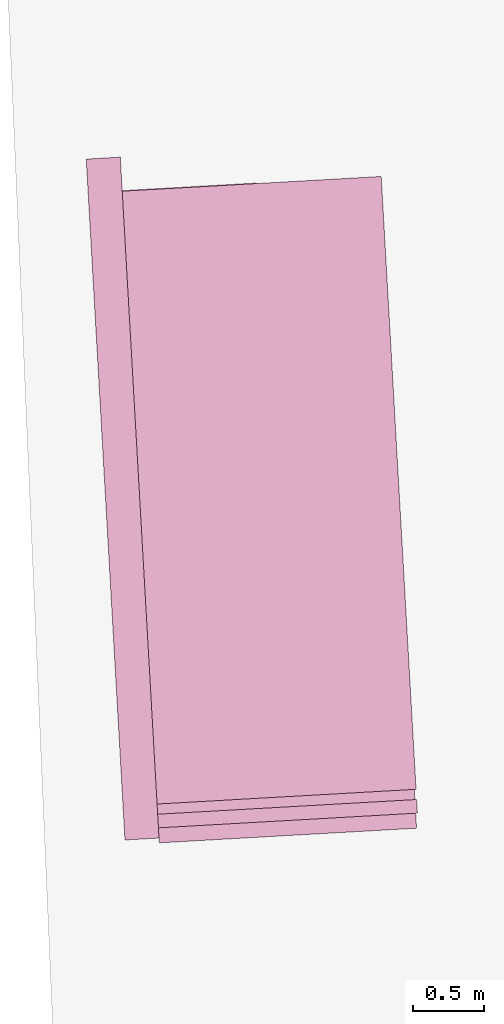
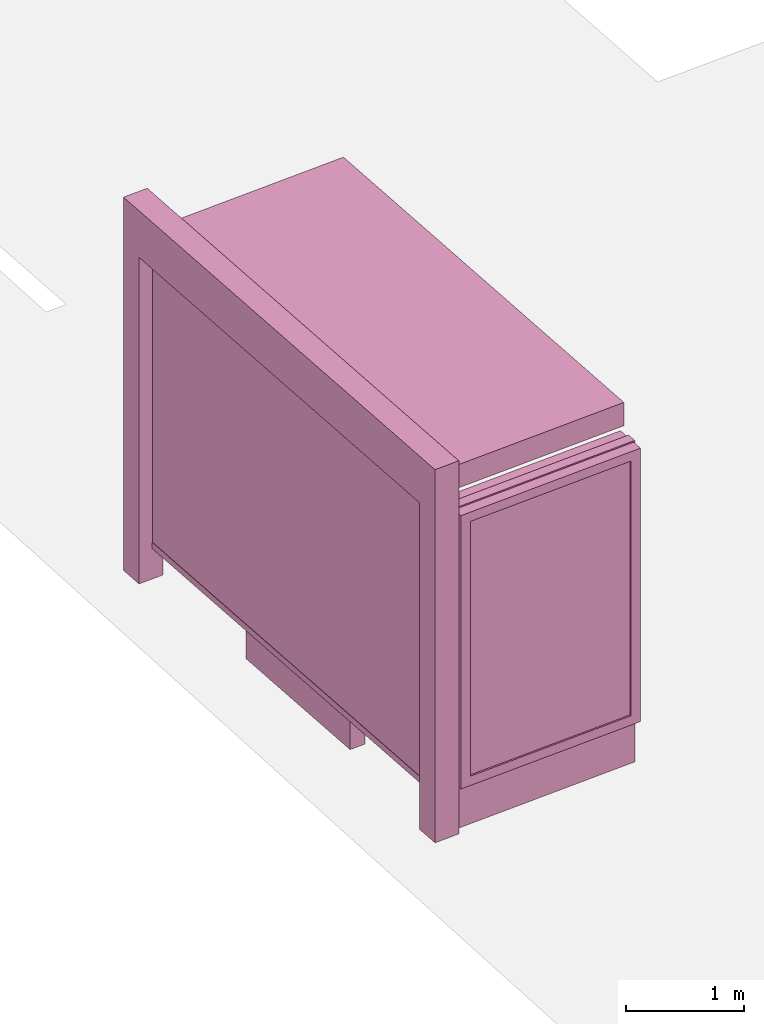
# One storey, part 31 of 200: 1 furnishing.
"""IFC4 building model written with IfcOpenShell, lengths in metres."""

from ifc_helpers import new_model, si_unit, origin_with_axes, place, context, subcontext, project, spatial, triangles, material, element, save


model = new_model("IFC4")

# Units and contexts
model_context = context("Model", 3, precision=1e-05, world=origin_with_axes())
body_context = subcontext(model_context, "Body", "Model", "MODEL_VIEW")
ifc_project = project(units=[si_unit("VOLUMEUNIT", "CUBIC_METRE"), si_unit("LENGTHUNIT", "METRE"), si_unit("AREAUNIT", "SQUARE_METRE")], contexts=[model_context])

# Site, building, storey
site_placement = place(None, origin_with_axes())
site = spatial("IfcSite", under=ifc_project, at=site_placement)
building_placement = place(site_placement, origin_with_axes())
building = spatial("IfcBuilding", under=site, at=building_placement, Name="Building")
storey_placement = place(building_placement, origin_with_axes())
storey = spatial("IfcBuildingStorey", under=building, at=storey_placement, Name="Ground")

# Furnishing
ifc_material = material(Name="busStop")
furnishing_placement = place(storey_placement, origin_with_axes())
element("IfcFurnishingElement", 1, at=furnishing_placement, inside=storey, material=ifc_material, Name="cw_instances_busStop_14", context=body_context, shape_type="Tessellation", body=[
    triangles([(385.01473330160724, -409.6272693210857, 3.3826375611235573), (382.69716299814627, -405.413360287961, 3.3826375611235573), (382.94357768705146, -409.74508782845345, 3.3826375611235573), (384.7683188112276, -405.29554159225097, 3.3826375611235573), (385.0147333978679, -409.62726931560974, 3.6236783199298275), (382.6971630944069, -405.4133602824851, 3.6236783199298275), (384.76831890748815, -405.2955415867751, 3.6236783199298275), (382.9435777833121, -409.74508782297755, 3.6236783199298275), (385.01473330160724, -409.6272693210857, 3.3826375611235573), (384.76831890748815, -405.2955415867751, 3.6236783199298275), (384.7683188112276, -405.29554159225097, 3.3826375611235573), (385.0147333978679, -409.62726931560974, 3.6236783199298275), (384.7683188112276, -405.29554159225097, 3.3826375611235573), (382.6971630944069, -405.4133602824851, 3.6236783199298275), (382.69716299814627, -405.413360287961, 3.3826375611235573), (384.76831890748815, -405.2955415867751, 3.6236783199298275), (382.69716299814627, -405.413360287961, 3.3826375611235573), (382.9435777833121, -409.74508782297755, 3.6236783199298275), (382.94357768705146, -409.74508782845345, 3.3826375611235573), (382.6971630944069, -405.4133602824851, 3.6236783199298275), (382.94357768705146, -409.74508782845345, 3.3826375611235573), (385.0147333978679, -409.62726931560974, 3.6236783199298275), (385.01473330160724, -409.6272693210857, 3.3826375611235573), (382.9435777833121, -409.74508782297755, 3.6236783199298275), (383.18422965349924, -409.731398045931, 3.864718677001767), (382.9572679193185, -409.98573949569595, 3.864718677001767), (382.9435781523111, -409.7450878019866, 3.864718677001767), (383.19791942050665, -409.97204973964034, 3.864718677001767), (383.18422965349924, -409.731398045931, 3.6236783199298275), (383.19791942050665, -409.97204973964034, 3.864718677001767), (383.18422965349924, -409.731398045931, 3.864718677001767), (383.19791942050665, -409.97204973964034, 3.6236783199298275), (382.92412541801576, -405.15901900842937, 3.6236783199298275), (382.6834737243064, -405.1727087754368, 3.864718677001767), (382.6834737243064, -405.1727087754368, 3.6236783199298275), (382.92412541801576, -405.15901900842937, 3.864718677001767), (382.69716347944933, -405.4133602605815, 3.6236783199298275), (382.6834737243064, -405.1727087754368, 3.864718677001767), (382.69716347944933, -405.4133602605815, 3.864718677001767), (382.6834737243064, -405.1727087754368, 3.6236783199298275), (382.9572677428407, -409.9857395057351, 3.6236783199298275), (383.19791942050665, -409.97204973964034, 3.864718677001767), (383.19791942050665, -409.97204973964034, 3.6236783199298275), (382.9572679193185, -409.98573949569595, 3.864718677001767), (382.9378149806375, -405.3996705045259, 3.864718677001767), (382.69716347944933, -405.4133602605815, 3.864718677001767), (382.9378149806375, -405.3996705045259, 3.6236783199298275), (382.9378149806375, -405.3996705045259, 3.864718677001767), (382.9572677428407, -409.9857395057351, 3.6236783199298275), (382.9435781523111, -409.7450878019866, 3.864718677001767), (382.9572679193185, -409.98573949569595, 3.864718677001767), (382.9435781523111, -409.7450878019866, 3.6236783199298275), (382.92412541801576, -405.15901900842937, 3.864718677001767), (382.6834737243064, -405.1727087754368, 3.864718677001767), (382.92412541801576, -405.15901900842937, 3.6236783199298275), (382.92412541801576, -405.15901900842937, 3.864718677001767), (382.9572668764952, -409.98573955501826, 9.480930192426488e-07), (383.19791828142274, -409.97204980443854, 8.998848996201414e-07), (382.94357710948776, -409.7450878613089, 9.480930192426488e-07), (382.9572668764952, -409.98573955501826, 9.480930192426488e-07), (382.9435781523111, -409.7450878019866, 3.6236783199298275), (383.1842286908931, -409.73139810069, 8.998848996201414e-07), (383.18422965349924, -409.731398045931, 3.6236783199298275), (382.94357710948776, -409.7450878613089, 9.480930192426488e-07), (383.19791828142274, -409.97204980443854, 8.998848996201414e-07), (383.1842286908931, -409.73139810069, 8.998848996201414e-07), (382.9241243495902, -405.1590205982666, 8.998848996201414e-07), (382.68347268148307, -405.1727088347591, 9.480930192426488e-07), (382.9378141056458, -405.3996720994547, 8.998848996201414e-07), (382.9241243495902, -405.1590205982666, 8.998848996201414e-07), (382.9378149806375, -405.3996705045259, 3.6236783199298275), (382.69716252424047, -405.41336186007356, 9.480930192426488e-07), (382.69716347944933, -405.4133602605815, 3.6236783199298275), (382.9378141056458, -405.3996720994547, 8.998848996201414e-07), (382.68347268148307, -405.1727088347591, 9.480930192426488e-07), (382.69716252424047, -405.41336186007356, 9.480930192426488e-07), (383.88770367532925, -405.3458858949335, 0.3459945917589383), (382.84312089693736, -405.40530826855456, 3.3826375611235573), (382.8431200305918, -405.4053083178377, 0.34599476852204364), (383.8877044614576, -405.34588585021356, 3.3826375611235573), (382.8440326802046, -405.4213517373459, 0.34599476852204364), (383.88861711107035, -405.3619292697218, 3.3826375611235573), (383.888616324942, -405.3619293144417, 0.3459945917589383), (382.8440335465501, -405.42135168806277, 3.3826375611235573), (383.888616324942, -405.3619293144417, 0.3459945917589383), (383.8877044614576, -405.34588585021356, 3.3826375611235573), (383.88770367532925, -405.3458858949335, 0.3459945917589383), (383.88861711107035, -405.3619292697218, 3.3826375611235573), (382.8442608483118, -405.42536269249445, 0.313856054245785), (383.8874754700435, -405.3418751350441, 0.3138558614133065), (382.8428918734364, -405.40129755521036, 0.313856054245785), (383.8888444449189, -405.36594027232815, 0.3138558614133065), (382.8442608483118, -405.42536269249445, 0.37813349886767544), (383.88747548608694, -405.34187513413144, 0.37813330603519696), (383.8888444609624, -405.3659402714155, 0.37813330603519696), (382.8428918734364, -405.40129755521036, 0.37813349886767544), (382.8442608483118, -405.42536269249445, 0.313856054245785), (383.8888444609624, -405.3659402714155, 0.37813330603519696), (383.8888444449189, -405.36594027232815, 0.3138558614133065), (382.8442608483118, -405.42536269249445, 0.37813349886767544), (383.8874754700435, -405.3418751350441, 0.3138558614133065), (382.8428918734364, -405.40129755521036, 0.37813349886767544), (382.8428918734364, -405.40129755521036, 0.313856054245785), (383.88747548608694, -405.34187513413144, 0.37813330603519696), (383.88747548608694, -405.34187513413144, 0.37813330603519696), (383.8888444449189, -405.36594027232815, 0.3138558614133065), (383.8888444609624, -405.3659402714155, 0.37813330603519696), (383.8874754700435, -405.3418751350441, 0.3138558614133065), (383.91072451835, -405.3609583209542, 0.37813330603519696), (383.8655956547004, -405.3468587939392, 0.37813330603519696), (383.9097794687309, -405.3443453434404, 0.37813330603519696), (383.86654070431945, -405.3634717714529, 0.37813330603519696), (383.910724261655, -405.3609583355566, 1.446243588675227e-07), (383.9097794687309, -405.3443453434404, 0.37813330603519696), (383.90977921203597, -405.34434535804286, 1.446243588675227e-07), (383.91072451835, -405.3609583209542, 0.37813330603519696), (383.90977921203597, -405.34434535804286, 1.446243588675227e-07), (383.8655956547004, -405.3468587939392, 0.37813330603519696), (383.86559554239636, -405.3468588003277, 1.6069373207502523e-07), (383.9097794687309, -405.3443453434404, 0.37813330603519696), (383.86559554239636, -405.3468588003277, 1.6069373207502523e-07), (383.86654070431945, -405.3634717714529, 0.37813330603519696), (383.8665405920154, -405.3634717778415, 1.6069373207502523e-07), (383.8655956547004, -405.3468587939392, 0.37813330603519696), (383.8665405920154, -405.3634717778415, 1.6069373207502523e-07), (383.91072451835, -405.3609583209542, 0.37813330603519696), (383.910724261655, -405.3609583355566, 1.446243588675227e-07), (383.86654070431945, -405.3634717714529, 0.37813330603519696), (383.17574922383153, -408.42319768548396, 1.1248564780513874), (382.9312955286171, -406.82756845430174, 1.1248565744676267), (383.08448465259517, -406.81885410293773, 1.1248564780513874), (383.0225602923747, -408.43191202589617, 1.1248565744676267), (383.08448446007395, -406.81885411388953, 4.981505694325782e-07), (383.17574922383153, -408.42319768548396, 0.964162810253855), (383.08448465259517, -406.81885410293773, 0.964162810253855), (383.1757488869194, -408.4231977046496, 4.981505694325782e-07), (382.93129514357463, -406.8275684762054, 5.302893158475833e-07), (383.08448465259517, -406.81885410293773, 0.964162810253855), (382.9312955286171, -406.82756845430174, 0.9641629066700942), (383.08448446007395, -406.81885411388953, 4.981505694325782e-07), (383.0225599073322, -408.4319120477998, 5.302893158475833e-07), (382.9312955286171, -406.82756845430174, 0.9641629066700942), (383.0225602923747, -408.43191202589617, 0.9641629066700942), (382.93129514357463, -406.8275684762054, 5.302893158475833e-07), (383.1757488869194, -408.4231977046496, 4.981505694325782e-07), (383.0225602923747, -408.43191202589617, 0.9641629066700942), (383.17574922383153, -408.42319768548396, 0.964162810253855), (383.0225599073322, -408.4319120477998, 5.302893158475833e-07), (383.72622201048813, -406.78234808557255, 1.124856381635148), (383.81748666194164, -408.38669166355555, 0.9641627138376155), (383.81748669402856, -408.38669166173025, 1.124856381635148), (383.7262219944447, -406.78234808648523, 0.9641627138376155), (382.9312955286171, -406.82756845430174, 1.1248565744676267), (383.08448465259517, -406.81885410293773, 1.1248564780513874), (383.0225602923747, -408.43191202589617, 1.1248565744676267), (382.9312955286171, -406.82756845430174, 1.1248565744676267), (383.17574922383153, -408.42319768548396, 1.1248564780513874), (383.0225602923747, -408.43191202589617, 1.1248565744676267), (383.81748669402856, -408.38669166173025, 1.124856381635148), (383.72622201048813, -406.78234808557255, 1.124856381635148), (383.81748666194164, -408.38669166355555, 0.9641627138376155), (383.81748669402856, -408.38669166173025, 1.124856381635148), (383.72622201048813, -406.78234808557255, 1.124856381635148), (383.7262219944447, -406.78234808648523, 0.9641627138376155), (383.1054747674994, -409.87577742394103, 0.34599476852204364), (382.84428358137967, -405.2842759426268, 3.503157940526693), (382.844282634817, -405.2842759964732, 0.34599476852204364), (383.1054754413237, -409.8757773856097, 3.503157940526693), (382.8282391992653, -405.28518864699856, 0.34599476852204364), (383.08943202181547, -409.87669003522245, 3.503157940526693), (383.08943134799114, -409.8766900735538, 0.34599476852204364), (382.82824016187146, -405.28518859223954, 3.503157940526693), (383.29518846917625, -409.9843194596568, 0.5810001600002933), (384.9209332935446, -409.8918369696478, 3.2193552137185355), (384.9209327159809, -409.8918370025032, 0.5809998707515756), (383.2951890788268, -409.98431942497604, 3.2193552137185355), (383.19984050547896, -410.00583878231737, 0.4845839046859049), (384.92184536559364, -409.90788042201143, 0.5809998707515756), (385.01810596934484, -409.9024060484614, 0.48458358329844076), (383.29610111878895, -410.000362879165, 0.5810001600002933), (384.92184594315734, -409.90788038915605, 3.2193552137185355), (385.01810674898854, -409.90240447505187, 3.3157713565473115), (383.2961017284395, -410.0003628444843, 3.2193552137185355), (383.1998411632598, -410.0058387448987, 3.3157713565473115), (383.29610111878895, -410.000362879165, 0.5810001600002933), (384.9209327159809, -409.8918370025032, 0.5809998707515756), (384.92184536559364, -409.90788042201143, 0.5809998707515756), (383.29518846917625, -409.9843194596568, 0.5810001600002933), (384.92184536559364, -409.90788042201143, 0.5809998707515756), (384.9209332935446, -409.8918369696478, 3.2193552137185355), (384.92184594315734, -409.90788038915605, 3.2193552137185355), (384.9209327159809, -409.8918370025032, 0.5809998707515756), (384.92184594315734, -409.90788038915605, 3.2193552137185355), (383.2951890788268, -409.98431942497604, 3.2193552137185355), (383.2961017284395, -410.0003628444843, 3.2193552137185355), (384.9209332935446, -409.8918369696478, 3.2193552137185355), (383.2961017284395, -410.0003628444843, 3.2193552137185355), (383.29518846917625, -409.9843194596568, 0.5810001600002933), (383.29610111878895, -410.000362879165, 0.5810001600002933), (383.2951890788268, -409.98431942497604, 3.2193552137185355), (385.00057272638986, -409.594174814633, 3.3157713565473115), (383.1998411632598, -410.0058387448987, 3.3157713565473115), (383.182307429443, -409.69760906805215, 3.3157713565473115), (385.01810674898854, -409.90240447505187, 3.3157713565473115), (385.0005718600444, -409.5941748639161, 0.48458358329844076), (385.01810674898854, -409.90240447505187, 3.3157713565473115), (385.00057272638986, -409.594174814633, 3.3157713565473115), (385.01810596934484, -409.9024060484614, 0.48458358329844076), (383.19984050547896, -410.00583878231737, 0.4845839046859049), (383.182307429443, -409.69760906805215, 3.3157713565473115), (383.1998411632598, -410.0058387448987, 3.3157713565473115), (383.18230665935806, -409.6976091118594, 0.4845839046859049), (383.27947989019395, -409.7081766300405, 0.5810001600002933), (384.9052245701714, -409.6156941482454, 3.2193552137185355), (383.2794806923657, -409.70817658440797, 3.2193552137185355), (384.9052239926077, -409.6156941811008, 0.5809998707515756), (383.18230665935806, -409.6976091118594, 0.4845839046859049), (384.90431134299496, -409.59965076159256, 0.5809998707515756), (383.2785672405812, -409.6921332105323, 0.5810001600002933), (385.0005718600444, -409.5941748639161, 0.48458358329844076), (384.90431192055865, -409.5996507287372, 3.2193552137185355), (385.00057272638986, -409.594174814633, 3.3157713565473115), (383.278568042753, -409.69213316489976, 3.2193552137185355), (383.182307429443, -409.69760906805215, 3.3157713565473115), (383.2785672405812, -409.6921332105323, 0.5810001600002933), (384.9052239926077, -409.6156941811008, 0.5809998707515756), (383.27947989019395, -409.7081766300405, 0.5810001600002933), (384.90431134299496, -409.59965076159256, 0.5809998707515756), (384.90431134299496, -409.59965076159256, 0.5809998707515756), (384.9052245701714, -409.6156941482454, 3.2193552137185355), (384.9052239926077, -409.6156941811008, 0.5809998707515756), (384.90431192055865, -409.5996507287372, 3.2193552137185355), (384.90431192055865, -409.5996507287372, 3.2193552137185355), (383.2794806923657, -409.70817658440797, 3.2193552137185355), (384.9052245701714, -409.6156941482454, 3.2193552137185355), (383.278568042753, -409.69213316489976, 3.2193552137185355), (383.278568042753, -409.69213316489976, 3.2193552137185355), (383.27947989019395, -409.7081766300405, 0.5810001600002933), (383.2794806923657, -409.70817658440797, 3.2193552137185355), (383.2785672405812, -409.6921332105323, 0.5810001600002933), (385.0243160362956, -409.7957237098174, 3.3287619342644956), (383.1883362031223, -409.8035936561646, 3.3287619342644956), (385.0188402253209, -409.69946471689445, 3.3287619342644956), (383.1938121007987, -409.89985417321395, 3.3287619342644956), (385.0243154601249, -409.79572546479636, 0.0), (385.0188402253209, -409.69946471689445, 3.3287619342644956), (385.0188395514966, -409.69946475522573, 0.0), (385.0243160362956, -409.7957237098174, 3.3287619342644956), (385.0188395514966, -409.69946475522573, 0.0), (383.1883362031223, -409.8035936561646, 3.3287619342644956), (383.1883354490808, -409.80359369905915, 5.142199426400808e-07), (385.0188402253209, -409.69946471689445, 3.3287619342644956), (383.1883354490808, -409.80359369905915, 5.142199426400808e-07), (383.1938121007987, -409.89985417321395, 3.3287619342644956), (383.19381134675723, -409.89985421610857, 5.142199426400808e-07), (383.1883362031223, -409.8035936561646, 3.3287619342644956), (383.19381134675723, -409.89985421610857, 5.142199426400808e-07), (385.0243160362956, -409.7957237098174, 3.3287619342644956), (385.0243154601249, -409.79572546479636, 0.0), (383.1938121007987, -409.89985417321395, 3.3287619342644956), (383.1094856263873, -409.8755492613097, 0.313856054245785), (382.82987929821047, -405.3847561146552, 0.313856054245785), (383.08542039284265, -409.87691824166103, 0.313856054245785), (382.85394441945107, -405.38338714069243, 0.313856054245785), (383.1094856263873, -409.8755492613097, 0.37813349886767544), (382.82987929821047, -405.3847561146552, 0.37813349886767544), (382.85394441945107, -405.38338714069243, 0.37813349886767544), (383.08542039284265, -409.87691824166103, 0.37813349886767544), (383.1094856263873, -409.8755492613097, 0.313856054245785), (382.85394441945107, -405.38338714069243, 0.37813349886767544), (382.85394441945107, -405.38338714069243, 0.313856054245785), (383.1094856263873, -409.8755492613097, 0.37813349886767544), (382.82987929821047, -405.3847561146552, 0.313856054245785), (383.08542039284265, -409.87691824166103, 0.37813349886767544), (383.08542039284265, -409.87691824166103, 0.313856054245785), (382.82987929821047, -405.3847561146552, 0.37813349886767544), (383.0143424920177, -408.2714254947254, 1.5290613779533648), (382.94133112289785, -406.9879505962173, 2.8146110577904615), (383.0143428770602, -408.27142547282176, 2.8146110577904615), (382.94133073785537, -406.98795061812086, 1.5290613779533648), (383.0260027083719, -408.23857146731507, 1.5612002850621018), (382.9566419271355, -407.0192703440131, 2.7824723435142027), (382.9566413656152, -407.0192703759559, 1.5612002850621018), (383.02600290089316, -408.2385714563632, 2.7824723435142027), (383.0143424920177, -408.2714254947254, 1.5290613779533648), (382.97085967568125, -406.9862708282446, 1.5290613779533648), (382.94133073785537, -406.98795061812086, 1.5290613779533648), (383.0438712373224, -408.26974571580087, 1.5290613779533648), (382.94133073785537, -406.98795061812086, 1.5290613779533648), (382.97085985215904, -406.9862708182054, 2.8146110577904615), (382.94133112289785, -406.9879505962173, 2.8146110577904615), (382.97085967568125, -406.9862708282446, 1.5290613779533648), (382.94133112289785, -406.9879505962173, 2.8146110577904615), (383.0438716223648, -408.2697456938973, 2.8146110577904615), (383.0143428770602, -408.27142547282176, 2.8146110577904615), (382.97085985215904, -406.9862708182054, 2.8146110577904615), (383.0143428770602, -408.27142547282176, 2.8146110577904615), (383.0438712373224, -408.26974571580087, 1.5290613779533648), (383.0143424920177, -408.2714254947254, 1.5290613779533648), (383.0438716223648, -408.2697456938973, 2.8146110577904615), (382.92001647753654, -406.61326835777925, 1.5290613779533648), (382.87438471587586, -405.8110964401281, 2.8146110577904615), (382.92001704962433, -406.61326822866323, 2.8146110577904615), (382.8743843308334, -405.8110964620317, 1.5290613779533648), (382.93167649315563, -406.58041419692984, 1.5612002850621018), (382.88969522859367, -405.8424161562213, 2.7824723435142027), (382.8896949398118, -405.84241617264905, 1.5612002850621018), (382.9316770546759, -406.580414164987, 2.7824723435142027), (382.92001647753654, -406.61326835777925, 1.5290613779533648), (382.90391306009457, -405.8094166840198, 1.5290613779533648), (382.8743843308334, -405.8110964620317, 1.5290613779533648), (382.9495454153624, -406.61158856790297, 1.5290613779533648), (382.8743843308334, -405.8110964620317, 1.5290613779533648), (382.90391344513705, -405.80941666211623, 2.8146110577904615), (382.87438471587586, -405.8110964401281, 2.8146110577904615), (382.90391306009457, -405.8094166840198, 1.5290613779533648), (382.87438471587586, -405.8110964401281, 2.8146110577904615), (382.9495457788855, -406.61158845065137, 2.8146110577904615), (382.92001704962433, -406.61326822866323, 2.8146110577904615), (382.90391344513705, -405.80941666211623, 2.8146110577904615), (382.92001704962433, -406.61326822866323, 2.8146110577904615), (382.9495454153624, -406.61158856790297, 1.5290613779533648), (382.92001647753654, -406.61326835777925, 1.5290613779533648), (382.9495457788855, -406.61158845065137, 2.8146110577904615), (383.0438712373224, -408.26974571580087, 1.5290613779533648), (382.97268488138405, -407.01835772086724, 1.5612002850621018), (382.97085967568125, -406.9862708282446, 1.5290613779533648), (383.0420459353589, -408.2376588286541, 1.5612002850621018), (382.9726851541225, -407.0183577053522, 2.7824723435142027), (382.97085985215904, -406.9862708182054, 2.8146110577904615), (383.04204632040137, -408.2376588067505, 2.7824723435142027), (383.0438716223648, -408.2697456938973, 2.8146110577904615), (382.9495454153624, -406.61158856790297, 1.5290613779533648), (382.9057383593201, -405.8415035230363, 1.5612002850621018), (382.90391306009457, -405.8094166840198, 1.5290613779533648), (382.9477201051851, -406.5795015363653, 1.5612002850621018), (382.9057387443625, -405.84150350113265, 2.7824723435142027), (382.90391344513705, -405.80941666211623, 2.8146110577904615), (382.9477204741841, -406.5795015153743, 2.7824723435142027), (382.9495457788855, -406.61158845065137, 2.8146110577904615), (383.0420459353589, -408.2376588286541, 1.5612002850621018), (382.9566413656152, -407.0192703759559, 1.5612002850621018), (382.97268488138405, -407.01835772086724, 1.5612002850621018), (383.0260027083719, -408.23857146731507, 1.5612002850621018), (382.97268488138405, -407.01835772086724, 1.5612002850621018), (382.9566419271355, -407.0192703440131, 2.7824723435142027), (382.9726851541225, -407.0183577053522, 2.7824723435142027), (382.9566413656152, -407.0192703759559, 1.5612002850621018), (382.9726851541225, -407.0183577053522, 2.7824723435142027), (383.02600290089316, -408.2385714563632, 2.7824723435142027), (383.04204632040137, -408.2376588067505, 2.7824723435142027), (382.9566419271355, -407.0192703440131, 2.7824723435142027), (383.04204632040137, -408.2376588067505, 2.7824723435142027), (383.0260027083719, -408.23857146731507, 1.5612002850621018), (383.0420459353589, -408.2376588286541, 1.5612002850621018), (383.02600290089316, -408.2385714563632, 2.7824723435142027), (382.9477201051851, -406.5795015363653, 1.5612002850621018), (382.8896949398118, -405.84241617264905, 1.5612002850621018), (382.9057383593201, -405.8415035230363, 1.5612002850621018), (382.93167649315563, -406.58041419692984, 1.5612002850621018), (382.9057383593201, -405.8415035230363, 1.5612002850621018), (382.88969522859367, -405.8424161562213, 2.7824723435142027), (382.9057387443625, -405.84150350113265, 2.7824723435142027), (382.8896949398118, -405.84241617264905, 1.5612002850621018), (382.9057387443625, -405.84150350113265, 2.7824723435142027), (382.9316770546759, -406.580414164987, 2.7824723435142027), (382.9477204741841, -406.5795015153743, 2.7824723435142027), (382.88969522859367, -405.8424161562213, 2.7824723435142027), (382.9477204741841, -406.5795015153743, 2.7824723435142027), (382.93167649315563, -406.58041419692984, 1.5612002850621018), (382.9477201051851, -406.5795015363653, 1.5612002850621018), (382.9316770546759, -406.580414164987, 2.7824723435142027)], [[1, 3, 2], [2, 4, 1], [5, 7, 6], [6, 8, 5], [9, 11, 10], [10, 12, 9], [13, 15, 14], [14, 16, 13], [17, 19, 18], [18, 20, 17], [21, 23, 22], [22, 24, 21], [25, 27, 26], [26, 28, 25], [29, 31, 30], [30, 32, 29], [33, 35, 34], [34, 36, 33], [37, 39, 38], [38, 40, 37], [41, 43, 42], [42, 44, 41], [45, 46, 27], [27, 25, 45], [47, 48, 31], [31, 29, 47], [49, 51, 50], [50, 52, 49], [52, 50, 39], [39, 37, 52], [53, 54, 46], [46, 45, 53], [55, 56, 48], [48, 47, 55], [43, 41, 57], [57, 58, 43], [49, 52, 59], [59, 60, 49], [61, 63, 62], [62, 64, 61], [29, 32, 65], [65, 66, 29], [35, 33, 67], [67, 68, 35], [55, 47, 69], [69, 70, 55], [71, 73, 72], [72, 74, 71], [37, 40, 75], [75, 76, 37], [77, 79, 78], [78, 80, 77], [81, 83, 82], [82, 84, 81], [85, 87, 86], [86, 88, 85], [89, 91, 90], [90, 92, 89], [93, 95, 94], [94, 96, 93], [97, 99, 98], [98, 100, 97], [101, 103, 102], [102, 104, 101], [105, 107, 106], [106, 108, 105], [109, 111, 110], [110, 112, 109], [113, 115, 114], [114, 116, 113], [117, 119, 118], [118, 120, 117], [121, 123, 122], [122, 124, 121], [125, 127, 126], [126, 128, 125], [129, 131, 130], [130, 132, 129], [133, 135, 134], [134, 136, 133], [137, 139, 138], [138, 140, 137], [141, 143, 142], [142, 144, 141], [145, 147, 146], [146, 148, 145], [149, 151, 150], [150, 152, 149], [153, 154, 138], [138, 139, 153], [155, 156, 142], [142, 143, 155], [157, 158, 146], [146, 147, 157], [131, 129, 159], [159, 160, 131], [157, 147, 161], [161, 162, 157], [138, 154, 163], [163, 164, 138], [165, 167, 166], [166, 168, 165], [169, 171, 170], [170, 172, 169], [173, 175, 174], [174, 176, 173], [177, 179, 178], [178, 180, 177], [179, 182, 181], [181, 178, 179], [182, 184, 183], [183, 181, 182], [184, 177, 180], [180, 183, 184], [185, 187, 186], [186, 188, 185], [189, 191, 190], [190, 192, 189], [193, 195, 194], [194, 196, 193], [197, 199, 198], [198, 200, 197], [201, 203, 202], [202, 204, 201], [205, 207, 206], [206, 208, 205], [209, 211, 210], [210, 212, 209], [213, 215, 214], [214, 216, 213], [217, 219, 218], [218, 220, 217], [220, 218, 221], [221, 222, 220], [222, 221, 223], [223, 224, 222], [224, 223, 219], [219, 217, 224], [225, 227, 226], [226, 228, 225], [229, 231, 230], [230, 232, 229], [233, 235, 234], [234, 236, 233], [237, 239, 238], [238, 240, 237], [241, 243, 242], [242, 244, 241], [245, 247, 246], [246, 248, 245], [249, 251, 250], [250, 252, 249], [253, 255, 254], [254, 256, 253], [257, 259, 258], [258, 260, 257], [261, 263, 262], [262, 264, 261], [265, 267, 266], [266, 268, 265], [269, 271, 270], [270, 272, 269], [273, 275, 274], [274, 276, 273], [277, 279, 278], [278, 280, 277], [281, 283, 282], [282, 284, 281], [285, 287, 286], [286, 288, 285], [289, 291, 290], [290, 292, 289], [293, 295, 294], [294, 296, 293], [297, 299, 298], [298, 300, 297], [301, 303, 302], [302, 304, 301], [305, 307, 306], [306, 308, 305], [309, 311, 310], [310, 312, 309], [313, 315, 314], [314, 316, 313], [317, 319, 318], [318, 320, 317], [321, 323, 322], [322, 324, 321], [325, 327, 326], [326, 328, 325], [327, 330, 329], [329, 326, 327], [330, 332, 331], [331, 329, 330], [332, 325, 328], [328, 331, 332], [333, 335, 334], [334, 336, 333], [335, 338, 337], [337, 334, 335], [338, 340, 339], [339, 337, 338], [340, 333, 336], [336, 339, 340], [341, 343, 342], [342, 344, 341], [345, 347, 346], [346, 348, 345], [349, 351, 350], [350, 352, 349], [353, 355, 354], [354, 356, 353], [357, 359, 358], [358, 360, 357], [361, 363, 362], [362, 364, 361], [365, 367, 366], [366, 368, 365], [369, 371, 370], [370, 372, 369]], closed=True),
])

save(model, "model.ifc")
